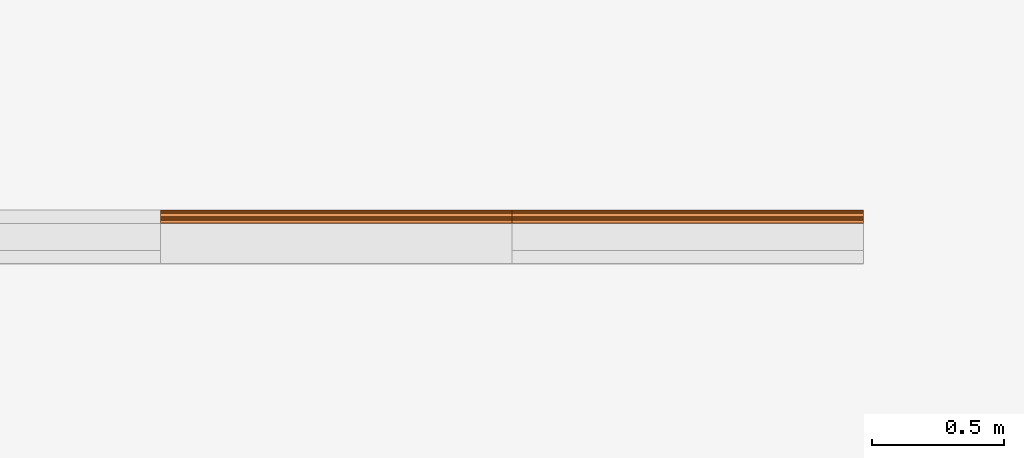
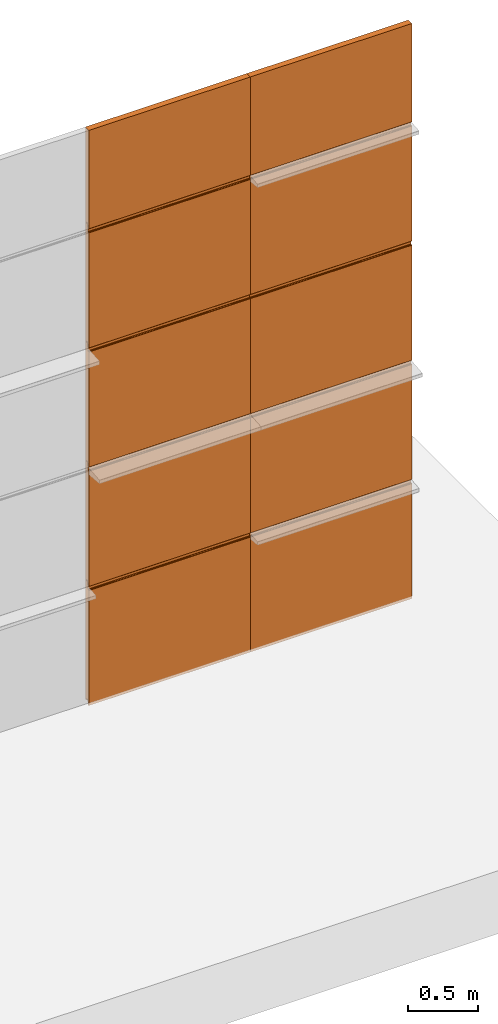
# One storey, part 6 of 6: 10 proxies.
"""IFC2X3 building model written with IfcOpenShell, lengths in millimetres."""

import ifcopenshell
import ifcopenshell.guid

model = None  # the IFC model being written
_history = None  # IfcOwnerHistory: only IFC2X3 demands one
_inside = {}  # id of a spatial element -> (the spatial element, [elements in it])
_under = {}  # id of a project, library or spatial element -> (it, [spatial elements below it])
_declared = {}  # id of a project -> (the project, [libraries it declares])
_typed = {}  # id of a type object -> (the type object, [elements of that type])
_made_of = {}  # id of a material, layer set ... -> (it, [elements and type objects made of it])


def new_model(schema):
    """Start an empty IFC model of exactly this schema.

    Asked for "IFC4X3", IfcOpenShell would pick the latest addendum, in which some entities
    have other attributes; the version numbers below select the first issue.
    IFC2X3 requires an IfcOwnerHistory on every rooted entity: one is made here for all.
    """
    global model, _history
    if schema == "IFC4X3":
        model = ifcopenshell.file(schema_version=(4, 3, 0, 0))
    else:
        model = ifcopenshell.file(schema=schema)
    _inside.clear()
    _under.clear()
    _declared.clear()
    _typed.clear()
    _made_of.clear()
    _history = None
    if model.schema == "IFC2X3":
        org = make("IfcOrganization", Name="unknown")
        user = make(
            "IfcPersonAndOrganization",
            ThePerson=make("IfcPerson", FamilyName="unknown"),
            TheOrganization=org,
        )
        app = make(
            "IfcApplication",
            ApplicationDeveloper=org,
            Version="unknown",
            ApplicationFullName="unknown",
            ApplicationIdentifier="unknown",
        )
        _history = make(
            "IfcOwnerHistory",
            OwningUser=user,
            OwningApplication=app,
            ChangeAction="ADDED",
            CreationDate=0,
        )
    return model


def make(cls, **values):
    """One entity of the class cls with the attributes given. An attribute that is None is left unset."""
    return model.create_entity(
        cls, **{name: value for name, value in values.items() if value is not None}
    )


def entity(cls, *values):
    """Any entity or typed value of the class cls, its attributes in the order of the schema. None: left unset."""
    e = model.create_entity(cls)
    for i, value in enumerate(values):
        if value is not None:
            e[i] = value
    return e


def rooted(cls, **values):
    """An entity with a GlobalId (a new one), such as an element, a storey or a relation."""
    return make(cls, GlobalId=ifcopenshell.guid.new(), OwnerHistory=_history, **values)


def si_unit(unit_type, name, prefix=None):
    """IfcSIUnit, for example si_unit("LENGTHUNIT", "METRE", prefix="MILLI")."""
    return make("IfcSIUnit", UnitType=unit_type, Prefix=prefix, Name=name)


def converted_unit(unit_type, name, factor, base, dimensions=None, offset=None):
    """IfcConversionBasedUnit, such as the inch: factor (a typed value) times the base unit."""
    return make(
        "IfcConversionBasedUnit"
        if offset is None
        else "IfcConversionBasedUnitWithOffset",
        ConversionOffset=offset,
        Dimensions=None
        if dimensions is None
        else entity("IfcDimensionalExponents", *dimensions),
        UnitType=unit_type,
        Name=name,
        ConversionFactor=make(
            "IfcMeasureWithUnit", ValueComponent=factor, UnitComponent=base
        ),
    )


def derived_unit(unit_type, elements):
    """IfcDerivedUnit: a product of units, each with its exponent."""
    return make(
        "IfcDerivedUnit",
        Elements=[
            make("IfcDerivedUnitElement", Unit=unit, Exponent=power)
            for unit, power in elements
        ],
        UnitType=unit_type,
    )


def assignment(units):
    """IfcUnitAssignment: the units of a project."""
    return None if units is None else make("IfcUnitAssignment", Units=units)


def point(xyz):
    """IfcCartesianPoint."""
    return None if xyz is None else make("IfcCartesianPoint", Coordinates=xyz)


def direction(xyz):
    """IfcDirection."""
    return None if xyz is None else make("IfcDirection", DirectionRatios=xyz)


def frame(location, z_axis=None, x_axis=None):
    """IfcAxis2Placement3D, a coordinate frame: its origin and axes. An axis left out is left unset."""
    return make(
        "IfcAxis2Placement3D",
        Location=point(location),
        Axis=direction(z_axis),
        RefDirection=direction(x_axis),
    )


def frame_2d(location, x_axis=None):
    """IfcAxis2Placement2D, a coordinate frame in the plane: its origin and x axis."""
    return make(
        "IfcAxis2Placement2D", Location=point(location), RefDirection=direction(x_axis)
    )


def origin():
    """The frame at (0, 0, 0) with its axes left unset."""
    return frame((0.0, 0.0, 0.0))


def place(relative_to, where):
    """IfcLocalPlacement: puts the frame where relative to a parent placement (None: the world)."""
    return make(
        "IfcLocalPlacement", PlacementRelTo=relative_to, RelativePlacement=where
    )


def context(
    kind, dimensions, precision=None, world=None, true_north=None, identifier=None
):
    """IfcGeometricRepresentationContext, for example the 3D "Model" context."""
    return make(
        "IfcGeometricRepresentationContext",
        ContextIdentifier=identifier,
        ContextType=kind,
        CoordinateSpaceDimension=dimensions,
        Precision=precision,
        WorldCoordinateSystem=world,
        TrueNorth=true_north,
    )


def subcontext(parent, identifier, kind, view, scale=None):
    """IfcGeometricRepresentationSubContext, for example "Body" below "Model"."""
    return make(
        "IfcGeometricRepresentationSubContext",
        ContextIdentifier=identifier,
        ContextType=kind,
        ParentContext=parent,
        TargetScale=scale,
        TargetView=view,
    )


def project(units=None, contexts=None):
    """IfcProject with its units and contexts."""
    return rooted(
        "IfcProject",
        Name="project",
        RepresentationContexts=contexts,
        UnitsInContext=assignment(units),
    )


def spatial(cls, under=None, at=None, **own):
    """A site, building, storey or space (cls), placed at a placement, below another one or the project."""
    s = rooted(cls, ObjectPlacement=at, **own)
    if under is not None:
        _under.setdefault(under.id(), (under, []))[1].append(s)
    return s


def polyline(points):
    """IfcPolyline through the points."""
    return make("IfcPolyline", Points=[point(p) for p in points])


def circle_curve(where, radius):
    """IfcCircle in the frame where."""
    return make("IfcCircle", Position=where, Radius=radius)


def parameter(value):
    """IfcParameterValue: where a trimmed curve begins or ends, as a parameter of its basis curve."""
    return model.create_entity("IfcParameterValue", value)


def trimmed(basis, trim1, trim2, sense, master):
    """IfcTrimmedCurve: the piece of a basis curve between two trims."""
    return make(
        "IfcTrimmedCurve",
        BasisCurve=basis,
        Trim1=trim1,
        Trim2=trim2,
        SenseAgreement=sense,
        MasterRepresentation=master,
    )


def segment(curve, same_sense, transition):
    """IfcCompositeCurveSegment."""
    return make(
        "IfcCompositeCurveSegment",
        Transition=transition,
        SameSense=same_sense,
        ParentCurve=curve,
    )


def composite_curve(segments, self_intersect=None):
    """IfcCompositeCurve: segments joined end to end."""
    return make("IfcCompositeCurve", Segments=segments, SelfIntersect=self_intersect)


def outline(outer, holes=None, kind="AREA"):
    """IfcArbitraryClosedProfileDef: a profile drawn as a closed curve; with holes, ...WithVoids."""
    if holes is None:
        return make("IfcArbitraryClosedProfileDef", ProfileType=kind, OuterCurve=outer)
    return make(
        "IfcArbitraryProfileDefWithVoids",
        ProfileType=kind,
        OuterCurve=outer,
        InnerCurves=holes,
    )


def extrude(swept, where, along, depth):
    """IfcExtrudedAreaSolid: the profile swept, set in the frame where, extruded along a direction by depth."""
    return make(
        "IfcExtrudedAreaSolid",
        SweptArea=swept,
        Position=where,
        ExtrudedDirection=direction(along),
        Depth=depth,
    )


def shape(context_of_items, identifier, shape_type, items):
    """IfcShapeRepresentation: the items that make up one representation, for example the "Body"."""
    return make(
        "IfcShapeRepresentation",
        ContextOfItems=context_of_items,
        RepresentationIdentifier=identifier,
        RepresentationType=shape_type,
        Items=items,
    )


def source(mapping_origin, context_of_items, identifier, shape_type, items):
    """IfcRepresentationMap: a shape defined once, which mapped items show again and again."""
    return make(
        "IfcRepresentationMap",
        MappingOrigin=mapping_origin,
        MappedRepresentation=shape(context_of_items, identifier, shape_type, items),
    )


def transform(
    local_origin,
    x_axis=None,
    y_axis=None,
    z_axis=None,
    scale=None,
    scale2=None,
    scale3=None,
    uniform=True,
):
    """IfcCartesianTransformationOperator3D, or its non-uniform kind. x_axis, y_axis, z_axis: its Axis1, 2, 3."""
    if uniform:
        return make(
            "IfcCartesianTransformationOperator3D",
            Axis1=direction(x_axis),
            Axis2=direction(y_axis),
            LocalOrigin=point(local_origin),
            Scale=scale,
            Axis3=direction(z_axis),
        )
    return make(
        "IfcCartesianTransformationOperator3DnonUniform",
        Axis1=direction(x_axis),
        Axis2=direction(y_axis),
        LocalOrigin=point(local_origin),
        Scale=scale,
        Axis3=direction(z_axis),
        Scale2=scale2,
        Scale3=scale3,
    )


def mapped(mapping_source, mapping_target):
    """IfcMappedItem: shows the shape of a source again, moved by a transform."""
    return make(
        "IfcMappedItem", MappingSource=mapping_source, MappingTarget=mapping_target
    )


def material(Name=None, Category=None):
    """IfcMaterial."""
    return make("IfcMaterial", Name=Name, Category=Category)


def made_of(thing, what):
    """Note that an element or type object is made of a material, layer set ...; save() writes the relation."""
    if what is not None:
        _made_of.setdefault(what.id(), (what, []))[1].append(thing)
    return thing


def type_object(cls, material=None, **own):
    """A type object (cls), such as IfcWallType, which elements share."""
    return made_of(rooted(cls, **own), material)


def type_shapes(of_type, sources):
    """Give a type object the sources (RepresentationMaps) that its elements show as mapped items."""
    of_type.RepresentationMaps = sources


def element(
    cls,
    number,
    at=None,
    inside=None,
    cuts=None,
    type_object=None,
    material=None,
    context=None,
    identifier="Body",
    shape_type=None,
    held_by="IfcProductDefinitionShape",
    body=None,
    shapes=None,
    **own,
):
    """One element of the class cls, such as IfcWall. Its Tag is "e" and its number.

    at: its placement. inside: the storey or other place that contains it. cuts: it is an
    opening in that element (IfcRelVoidsElement). A single representation is given by context,
    identifier, shape_type and body (its items); several are given by shapes. held_by: the class
    of the entity that holds the representations. save() writes the other relations.
    """
    e = rooted(cls, Tag="e%d" % number, ObjectPlacement=at, **own)
    if body is not None:
        shapes = [shape(context, identifier, shape_type, body)]
    if shapes is not None:
        e.Representation = make(held_by, Representations=shapes)
    if inside is not None:
        _inside.setdefault(inside.id(), (inside, []))[1].append(e)
    if cuts is not None:
        rooted(
            "IfcRelVoidsElement", RelatingBuildingElement=cuts, RelatedOpeningElement=e
        )
    if type_object is not None:
        _typed.setdefault(type_object.id(), (type_object, []))[1].append(e)
    return made_of(e, material)


def aggregate(whole, parts):
    """IfcRelAggregates: a whole, such as a stair, and the parts it consists of."""
    return rooted("IfcRelAggregates", RelatingObject=whole, RelatedObjects=parts)


def save(model, path):
    """Write the relations noted so far, then the file.

    IfcRelAggregates (storeys below a building ...), IfcRelContainedInSpatialStructure (elements
    in a storey), IfcRelDefinesByType, IfcRelAssociatesMaterial and IfcRelDeclares: one each for
    every whole, place, type object, material and project.
    """
    for whole, parts in _under.values():
        aggregate(whole, parts)
    for where, things in _inside.values():
        rooted(
            "IfcRelContainedInSpatialStructure",
            RelatedElements=things,
            RelatingStructure=where,
        )
    for kind, things in _typed.values():
        rooted("IfcRelDefinesByType", RelatedObjects=things, RelatingType=kind)
    for what, things in _made_of.values():
        rooted("IfcRelAssociatesMaterial", RelatedObjects=things, RelatingMaterial=what)
    for by, libraries in _declared.values():
        rooted("IfcRelDeclares", RelatingContext=by, RelatedDefinitions=libraries)
    model.write(path)


model = new_model("IFC2X3")

# Units and contexts
model_context = context("Model", 3, precision=0.01, world=origin(), true_north=direction((6.123031769111886e-17, 1.0)))
body_context = subcontext(model_context, "Body", "Model", "MODEL_VIEW")
ifc_project = project(units=[si_unit("LENGTHUNIT", "METRE", prefix="MILLI"), si_unit("AREAUNIT", "SQUARE_METRE"), si_unit("VOLUMEUNIT", "CUBIC_METRE"), converted_unit("PLANEANGLEUNIT", "DEGREE", entity("IfcPlaneAngleMeasure", 0.017453292519943278), si_unit("PLANEANGLEUNIT", "RADIAN"), dimensions=[0, 0, 0, 0, 0, 0, 0]), si_unit("MASSUNIT", "GRAM", prefix="KILO"), derived_unit("MASSDENSITYUNIT", [(si_unit("MASSUNIT", "GRAM", prefix="KILO"), 1), (si_unit("LENGTHUNIT", "METRE"), -3)]), derived_unit("IONCONCENTRATIONUNIT", [(si_unit("MASSUNIT", "GRAM", prefix="KILO"), 1), (si_unit("LENGTHUNIT", "METRE"), -3)]), derived_unit("MOMENTOFINERTIAUNIT", [(si_unit("LENGTHUNIT", "METRE"), 4)]), si_unit("TIMEUNIT", "SECOND"), si_unit("FREQUENCYUNIT", "HERTZ"), si_unit("THERMODYNAMICTEMPERATUREUNIT", "DEGREE_CELSIUS"), derived_unit("THERMALTRANSMITTANCEUNIT", [(si_unit("MASSUNIT", "GRAM", prefix="KILO"), 1), (si_unit("THERMODYNAMICTEMPERATUREUNIT", "KELVIN"), -1), (si_unit("TIMEUNIT", "SECOND"), -3)]), derived_unit("THERMALCONDUCTANCEUNIT", [(si_unit("MASSUNIT", "GRAM", prefix="KILO"), 1), (si_unit("THERMODYNAMICTEMPERATUREUNIT", "KELVIN"), -1), (si_unit("TIMEUNIT", "SECOND"), -3), (si_unit("LENGTHUNIT", "METRE"), 1)]), derived_unit("VOLUMETRICFLOWRATEUNIT", [(si_unit("LENGTHUNIT", "METRE", prefix="DECI"), 3), (si_unit("TIMEUNIT", "SECOND"), -1)]), derived_unit("MASSFLOWRATEUNIT", [(si_unit("MASSUNIT", "GRAM", prefix="KILO"), 1), (si_unit("TIMEUNIT", "SECOND"), -1)]), derived_unit("ROTATIONALFREQUENCYUNIT", [(si_unit("TIMEUNIT", "SECOND"), -1)]), si_unit("ELECTRICCURRENTUNIT", "AMPERE"), si_unit("ELECTRICVOLTAGEUNIT", "VOLT"), si_unit("POWERUNIT", "WATT"), si_unit("FORCEUNIT", "NEWTON", prefix="KILO"), si_unit("ILLUMINANCEUNIT", "LUX"), si_unit("LUMINOUSFLUXUNIT", "LUMEN"), si_unit("LUMINOUSINTENSITYUNIT", "CANDELA"), si_unit("ENERGYUNIT", "JOULE"), derived_unit("USERDEFINED", [(si_unit("MASSUNIT", "GRAM", prefix="KILO"), -1), (si_unit("LENGTHUNIT", "METRE"), -2), (si_unit("TIMEUNIT", "SECOND"), 3), (si_unit("LUMINOUSFLUXUNIT", "LUMEN"), 1)]), derived_unit("USERDEFINED", [(si_unit("MASSUNIT", "GRAM", prefix="KILO"), 1), (si_unit("TIMEUNIT", "SECOND"), -3), (si_unit("LENGTHUNIT", "METRE"), 3), (si_unit("ELECTRICCURRENTUNIT", "AMPERE"), -2)]), derived_unit("SOUNDPOWERUNIT", [(si_unit("MASSUNIT", "GRAM", prefix="KILO"), 1), (si_unit("TIMEUNIT", "SECOND"), -3), (si_unit("LENGTHUNIT", "METRE"), 2)]), derived_unit("SOUNDPRESSUREUNIT", [(si_unit("MASSUNIT", "GRAM", prefix="KILO"), 1), (si_unit("LENGTHUNIT", "METRE"), -1), (si_unit("TIMEUNIT", "SECOND"), -2)]), derived_unit("LINEARVELOCITYUNIT", [(si_unit("LENGTHUNIT", "METRE"), 1), (si_unit("TIMEUNIT", "SECOND"), -1)]), si_unit("PRESSUREUNIT", "PASCAL"), derived_unit("USERDEFINED", [(si_unit("MASSUNIT", "GRAM", prefix="KILO"), 1), (si_unit("LENGTHUNIT", "METRE"), -2), (si_unit("TIMEUNIT", "SECOND"), -2)]), derived_unit("LINEARFORCEUNIT", [(si_unit("MASSUNIT", "GRAM", prefix="KILO"), 1), (si_unit("TIMEUNIT", "SECOND"), -2)]), derived_unit("PLANARFORCEUNIT", [(si_unit("MASSUNIT", "GRAM", prefix="KILO"), 1), (si_unit("LENGTHUNIT", "METRE"), -1), (si_unit("TIMEUNIT", "SECOND"), -2)]), derived_unit("SPECIFICHEATCAPACITYUNIT", [(si_unit("THERMODYNAMICTEMPERATUREUNIT", "KELVIN"), -1), (si_unit("LENGTHUNIT", "METRE"), 2), (si_unit("TIMEUNIT", "SECOND"), -2)]), derived_unit("HEATFLUXDENSITYUNIT", [(si_unit("MASSUNIT", "GRAM", prefix="KILO"), 1), (si_unit("TIMEUNIT", "SECOND"), -3)]), derived_unit("HEATINGVALUEUNIT", [(si_unit("LENGTHUNIT", "METRE"), 2), (si_unit("TIMEUNIT", "SECOND"), -2)]), derived_unit("VAPORPERMEABILITYUNIT", [(si_unit("LENGTHUNIT", "METRE"), -1), (si_unit("TIMEUNIT", "SECOND"), 1)]), derived_unit("DYNAMICVISCOSITYUNIT", [(si_unit("MASSUNIT", "GRAM", prefix="KILO"), 1), (si_unit("TIMEUNIT", "SECOND"), -1), (si_unit("LENGTHUNIT", "METRE"), -1)]), derived_unit("THERMALEXPANSIONCOEFFICIENTUNIT", [(si_unit("THERMODYNAMICTEMPERATUREUNIT", "KELVIN"), -1)]), derived_unit("MODULUSOFELASTICITYUNIT", [(si_unit("MASSUNIT", "GRAM", prefix="KILO"), 1), (si_unit("LENGTHUNIT", "METRE"), -1), (si_unit("TIMEUNIT", "SECOND"), -2)]), derived_unit("ISOTHERMALMOISTURECAPACITYUNIT", [(si_unit("MASSUNIT", "GRAM", prefix="KILO"), -1), (si_unit("LENGTHUNIT", "METRE"), 3)]), derived_unit("MOISTUREDIFFUSIVITYUNIT", [(si_unit("TIMEUNIT", "SECOND"), -1), (si_unit("LENGTHUNIT", "METRE"), 2)]), derived_unit("MASSPERLENGTHUNIT", [(si_unit("MASSUNIT", "GRAM", prefix="KILO"), 1), (si_unit("LENGTHUNIT", "METRE"), -1)]), derived_unit("THERMALRESISTANCEUNIT", [(si_unit("MASSUNIT", "GRAM", prefix="KILO"), -1), (si_unit("TIMEUNIT", "SECOND"), 3), (si_unit("THERMODYNAMICTEMPERATUREUNIT", "KELVIN"), 1)]), derived_unit("ACCELERATIONUNIT", [(si_unit("LENGTHUNIT", "METRE"), 1), (si_unit("TIMEUNIT", "SECOND"), -2)]), derived_unit("ANGULARVELOCITYUNIT", [(si_unit("TIMEUNIT", "SECOND"), -1), (si_unit("PLANEANGLEUNIT", "RADIAN"), 1)]), derived_unit("LINEARSTIFFNESSUNIT", [(si_unit("MASSUNIT", "GRAM", prefix="KILO"), 1), (si_unit("TIMEUNIT", "SECOND"), -2)]), derived_unit("WARPINGCONSTANTUNIT", [(si_unit("LENGTHUNIT", "METRE"), 6)]), derived_unit("LINEARMOMENTUNIT", [(si_unit("MASSUNIT", "GRAM", prefix="KILO"), 1), (si_unit("LENGTHUNIT", "METRE"), 1), (si_unit("TIMEUNIT", "SECOND"), -2)]), derived_unit("TORQUEUNIT", [(si_unit("MASSUNIT", "GRAM", prefix="KILO"), 1), (si_unit("LENGTHUNIT", "METRE"), 2), (si_unit("TIMEUNIT", "SECOND"), -2)])], contexts=[model_context])

# Site, building, storey
site_placement = place(None, origin())
site = spatial("IfcSite", under=ifc_project, at=site_placement, CompositionType="ELEMENT")
building_placement = place(site_placement, origin())
building = spatial("IfcBuilding", under=site, at=building_placement, Name="de", CompositionType="ELEMENT")
storey_placement = place(building_placement, origin())
storey = spatial("IfcBuildingStorey", under=building, at=storey_placement, CompositionType="ELEMENT", Elevation=0.0)

# Proxies
ifc_material = material(Name="KSI_RAL9003")
building_element_proxy_type_1 = type_object("IfcBuildingElementProxyType", Name="Painel Evolution:Painel Evolution", PredefinedType="NOTDEFINED", material=ifc_material)
shared_shape_1 = source(origin(), body_context, "Body", "SweptSolid", [
    extrude(outline(composite_curve([segment(trimmed(circle_curve(frame_2d((-541.6373700065079, 10.459449795313603), x_axis=(-1.0, 0.0)), 1.5999999047686129), [parameter(279.9999998873789)], [parameter(358.50454829316124)], True, "PARAMETER"), True, "CONTINUOUS"), segment(polyline([(-543.2368249510248, 10.501205941207395), (-543.2368249510248, 3.880596964632579)]), True, "CONTINUOUS"), segment(trimmed(circle_curve(frame_2d((-542.1914107086996, 3.880596964632576), x_axis=(-1.0, 0.0)), 1.0454142423252974), [parameter(359.9999999999996)], [parameter(90.00000000000009)], True, "PARAMETER"), True, "CONTINUOUS"), segment(polyline([(-542.1914107086996, 2.83518272230729), (-534.2753031299127, 2.835182722321888)]), True, "CONTINUOUS"), segment(trimmed(circle_curve(frame_2d((-534.2753031299127, 0.485182810658933), x_axis=(-1.0, 0.0)), 2.3499999116629553), [parameter(180.00000000000043)], [parameter(269.9999999999999)], True, "PARAMETER"), False, "CONTINUOUS"), segment(polyline([(-531.9253032182644, 0.4851828106589372), (-531.9253032182644, -3.9178716254091968)]), True, "CONTINUOUS"), segment(trimmed(circle_curve(frame_2d((-534.275303129929, -3.917871625409184), x_axis=(-1.0, 0.0)), 2.3499999116645798), [parameter(90.00000000000009)], [parameter(180.0)], True, "PARAMETER"), False, "CONTINUOUS"), segment(polyline([(-534.275303129929, -6.267871537073788), (-544.9447939910186, -6.267871537074008)]), True, "CONTINUOUS"), segment(trimmed(circle_curve(frame_2d((-544.9447939910186, -8.667871537069942), x_axis=(-1.0, 0.0)), 2.399999999995935), [parameter(269.9999999999999)], [parameter(359.99999999999966)], True, "PARAMETER"), True, "CONTINUOUS"), segment(polyline([(-547.3447939910149, -8.667871537069942), (-547.3447939910149, -10.667871311477809)]), True, "CONTINUOUS"), segment(trimmed(circle_curve(frame_2d((-548.9447939910189, -10.667871311477805), x_axis=(-1.0, 0.0)), 1.6000000000039678), [parameter(90.00000000000009)], [parameter(180.0000000000002)], True, "PARAMETER"), False, "CONTINUOUS"), segment(polyline([(-548.9447939910189, -12.267871311481763), (-572.3355503541303, -12.26787131148627)]), True, "CONTINUOUS"), segment(trimmed(circle_curve(frame_2d((-572.3355503541303, -15.967871172331035), x_axis=(-1.0, 0.0)), 3.699999860844765), [parameter(269.9999999999999)], [parameter(350.4980187502896)], True, "PARAMETER"), True, "CONTINUOUS"), segment(polyline([(-575.9847858236225, -15.357068865127594), (-576.4262167541286, -20.400087371498177)]), True, "CONTINUOUS"), segment(trimmed(circle_curve(frame_2d((-572.8754972220172, -20.700390565940353), x_axis=(-1.0, 0.0)), 3.5633960212569518), [parameter(355.16569651713564)], [parameter(88.83791988883837)], True, "PARAMETER"), True, "CONTINUOUS"), segment(polyline([(-572.9477655073729, -24.26305368488658), (429.0782903905062, -24.26305368490059)]), True, "CONTINUOUS"), segment(trimmed(circle_curve(frame_2d((429.02661432000133, -21.373687559574048), x_axis=(-1.0, 0.0)), 2.889828199469197), [parameter(91.024620965678)], [parameter(174.99921945634426)], True, "PARAMETER"), True, "CONTINUOUS"), segment(polyline([(431.90544241925767, -21.625591901172886), (432.65194514225794, -13.094365331982997)]), True, "CONTINUOUS"), segment(trimmed(circle_curve(frame_2d((434.6718091241544, -13.271108258981247), x_axis=(-1.0, 0.0)), 2.0275819508977904), [parameter(322.50238491495514)], [parameter(354.9992194748408)], True, "PARAMETER"), False, "CONTINUOUS"), segment(trimmed(circle_curve(frame_2d((434.6499261921662, -13.25431834245234), x_axis=(-1.0, 0.0)), 2.000000000331924), [parameter(269.7752197054467)], [parameter(322.50238490067886)], True, "PARAMETER"), False, "CONTINUOUS"), segment(polyline([(434.6577724845074, -11.254333733262063), (464.6446978830772, -11.254333733258877)]), True, "CONTINUOUS"), segment(trimmed(circle_curve(frame_2d((464.6446978830757, -8.454333717516795), x_axis=(-1.0, 0.0)), 2.8000000157420852), [parameter(90.00000000003057)], [parameter(180.00000000002854)], True, "PARAMETER"), True, "CONTINUOUS"), segment(polyline([(467.4446978988198, -8.45433371751389), (467.44469789904696, -6.163773190028205)]), True, "CONTINUOUS"), segment(trimmed(circle_curve(frame_2d((470.4446979072005, -6.163773190028211), x_axis=(-1.0, 0.0)), 3.000000008153628), [parameter(269.9999999999947)], [parameter(4.0711099922733055e-13)], True, "PARAMETER"), False, "CONTINUOUS"), segment(polyline([(470.4446979072011, -3.1637731816474877), (492.4821726913916, -3.1637731816475423)]), True, "CONTINUOUS"), segment(trimmed(circle_curve(frame_2d((492.4821726913916, -4.763773183527278), x_axis=(-1.0, 0.0)), 1.6000000018797356), [parameter(221.0795546756581)], [parameter(270.00000000000233)], True, "PARAMETER"), False, "CONTINUOUS"), segment(trimmed(circle_curve(frame_2d((496.43523715110086, -1.9925479235228443), x_axis=(-1.0, 0.0)), 3.2409633915334344), [parameter(32.05017476117218)], [parameter(61.522805713472586)], True, "PARAMETER"), True, "CONTINUOUS"), segment(trimmed(circle_curve(frame_2d((496.00254394635044, -2.714863509877051), x_axis=(-1.0, 0.0)), 2.4000000000014894), [parameter(62.38069466751207)], [parameter(92.2671756846998)], True, "PARAMETER"), True, "CONTINUOUS"), segment(polyline([(496.0974863986537, -5.11298484349589), (504.442623351026, -5.112984843495904)]), True, "CONTINUOUS"), segment(trimmed(circle_curve(frame_2d((504.4426233510259, -1.8442935298604415), x_axis=(-1.0, 0.0)), 3.268691313635463), [parameter(90.00000000000126)], [parameter(266.64922463269517)], True, "PARAMETER"), True, "CONTINUOUS"), segment(polyline([(504.63367421393616, 1.4188096667328296), (496.7914226707592, 1.4188096667328491)]), True, "CONTINUOUS"), segment(polyline([(496.7914226707592, 1.4188096667328491), (496.79142267075923, 13.229214081882997)]), True, "CONTINUOUS"), segment(polyline([(496.79142267075923, 13.229214081882997), (500.32479033585236, 13.22921408188327)]), True, "CONTINUOUS"), segment(trimmed(circle_curve(frame_2d((499.51496654021736, 16.736946315110515), x_axis=(-1.0, 0.0)), 3.599999999999723), [parameter(102.99999999995242)], [parameter(269.99999999999886)], True, "PARAMETER"), True, "CONTINUOUS"), segment(polyline([(499.5149665402175, 20.336946315110506), (489.7149665402197, 20.33694631511163)]), True, "CONTINUOUS"), segment(trimmed(circle_curve(frame_2d((489.7149665402197, 22.336946315111717), x_axis=(-1.0, 0.0)), 2.0000000000000866), [parameter(3.5622212432391423e-13)], [parameter(90.00000000000202)], True, "PARAMETER"), False, "CONTINUOUS"), segment(polyline([(487.71496654021854, 22.336946315111724), (487.71496654021854, 23.736946315111506)]), True, "CONTINUOUS"), segment(trimmed(circle_curve(frame_2d((485.7149665402189, 23.73694631511151), x_axis=(-1.0, 0.0)), 1.9999999999995453), [parameter(179.99999999999983)], [parameter(269.99999999999795)], True, "PARAMETER"), True, "CONTINUOUS"), segment(polyline([(485.7149665402189, 25.736946315111073), (-547.7850334597792, 25.736946315115553)]), True, "CONTINUOUS"), segment(trimmed(circle_curve(frame_2d((-547.7850334597792, 23.23694631511558), x_axis=(-1.0, 0.0)), 2.499999999999973), [parameter(269.9999999999999)], [parameter(90.00000000000009)], True, "PARAMETER"), True, "CONTINUOUS"), segment(polyline([(-547.7850334597794, 20.736946315117518), (-538.5134802227543, 20.736946315115397)]), True, "CONTINUOUS"), segment(trimmed(circle_curve(frame_2d((-538.5134802227543, 16.38604421100607), x_axis=(-1.0, 0.0)), 4.350902104109325), [parameter(90.00000000000009)], [parameter(269.9999999999999)], True, "PARAMETER"), False, "CONTINUOUS"), segment(polyline([(-538.5134802227543, 12.03514210689464), (-541.9152070711411, 12.03514210689464)]), True, "CONTINUOUS")], self_intersect=False)), frame((-30.32409595977936, -0.7369463151145117, 0.0), z_axis=(0.0, 0.0, -1.0), x_axis=(-1.0, 0.0, 0.0)), (0.0, 0.0, -1.0), 1333.3333333333342),
])
type_shapes(building_element_proxy_type_1, [shared_shape_1])
for number, where, z_axis, x_axis, name in (
    (1, (1654.667810641471, 792.6007792258418, 520.0), (1.0, 0.0, 0.0), (0.0, 0.0, -1.0), "Painel Evolution:Painel Evolution"),
    (2, (1654.667810641471, 792.6007792258426, 1560.0), (1.0, 0.0, 0.0), (0.0, 0.0, -1.0), "Painel Evolution:Painel Evolution"),
    (3, (1654.667810641471, 792.6007792258426, 2600.0), (1.0, 0.0, 0.0), (0.0, 0.0, -1.0), "Painel Evolution:Painel Evolution"),
    (4, (1654.667810641471, 792.6007792258426, 3640.0), (1.0, 0.0, 0.0), (0.0, 0.0, -1.0), "Painel Evolution:Painel Evolution"),
    (5, (2988.0011439748046, 792.6007792258396, 520.0), (1.0, 0.0, 0.0), (0.0, 0.0, -1.0), "Painel Evolution:Painel Evolution"),
    (6, (2988.0011439748046, 792.6007792258396, 1560.0), (1.0, 0.0, 0.0), (0.0, 0.0, -1.0), "Painel Evolution:Painel Evolution"),
    (7, (2988.0011439748046, 792.6007792258396, 2600.0), (1.0, 0.0, 0.0), (0.0, 0.0, -1.0), "Painel Evolution:Painel Evolution"),
    (8, (2988.0011439748046, 792.6007792258396, 3640.0), (1.0, 0.0, 0.0), (0.0, 0.0, -1.0), "Painel Evolution:Painel Evolution"),
):
    element("IfcBuildingElementProxy", number, at=place(storey_placement, frame(where, z_axis=z_axis, x_axis=x_axis)), inside=storey, type_object=building_element_proxy_type_1, material=ifc_material, Name=name, ObjectType="Painel Evolution:Painel Evolution", context=body_context, shape_type="MappedRepresentation", body=[
        mapped(shared_shape_1, transform((0.0, 0.0, 0.0), scale=1.0)),
    ])
building_element_proxy_type_2 = type_object("IfcBuildingElementProxyType", Name="Painel Evolution:Painel Evolution", PredefinedType="NOTDEFINED", material=ifc_material)
shared_shape_2 = source(origin(), body_context, "Body", "SweptSolid", [
    extrude(outline(composite_curve([segment(trimmed(circle_curve(frame_2d((-69.24830272831227, 10.78003811995571), x_axis=(-1.0, 0.0)), 1.5999999047686129), [parameter(279.9999998873789)], [parameter(358.50454829316124)], True, "PARAMETER"), True, "CONTINUOUS"), segment(polyline([(-70.84775767282915, 10.821794265849501), (-70.84775767282916, 4.201185289274686)]), True, "CONTINUOUS"), segment(trimmed(circle_curve(frame_2d((-69.80234343050391, 4.201185289274683), x_axis=(-1.0, 0.0)), 1.0454142423252974), [parameter(359.9999999999996)], [parameter(90.00000000000009)], True, "PARAMETER"), True, "CONTINUOUS"), segment(polyline([(-69.80234343050385, 3.1557710469493974), (-61.88623585171705, 3.1557710469639955)]), True, "CONTINUOUS"), segment(trimmed(circle_curve(frame_2d((-61.88623585171706, 0.8057711353010405), x_axis=(-1.0, 0.0)), 2.3499999116629553), [parameter(180.00000000000043)], [parameter(269.9999999999999)], True, "PARAMETER"), False, "CONTINUOUS"), segment(polyline([(-59.536235940068764, 0.8057711353010448), (-59.53623594006877, -3.59728330076709)]), True, "CONTINUOUS"), segment(trimmed(circle_curve(frame_2d((-61.886235851733325, -3.5972833007670766), x_axis=(-1.0, 0.0)), 2.3499999116645798), [parameter(90.00000000000009)], [parameter(180.0)], True, "PARAMETER"), False, "CONTINUOUS"), segment(polyline([(-61.88623585173333, -5.947283212431681), (-72.55572671282302, -5.947283212431901)]), True, "CONTINUOUS"), segment(trimmed(circle_curve(frame_2d((-72.55572671282302, -8.347283212427834), x_axis=(-1.0, 0.0)), 2.399999999995935), [parameter(269.9999999999999)], [parameter(359.99999999999966)], True, "PARAMETER"), True, "CONTINUOUS"), segment(polyline([(-74.95572671281924, -8.347283212427834), (-74.95572671281926, -10.347282986835701)]), True, "CONTINUOUS"), segment(trimmed(circle_curve(frame_2d((-76.55572671282326, -10.3472829868357), x_axis=(-1.0, 0.0)), 1.6000000000039678), [parameter(90.00000000000009)], [parameter(180.0000000000002)], True, "PARAMETER"), False, "CONTINUOUS"), segment(polyline([(-76.55572671282326, -11.947282986839657), (-99.94648307593471, -11.947282986844161)]), True, "CONTINUOUS"), segment(trimmed(circle_curve(frame_2d((-99.94648307593472, -15.647282847688928), x_axis=(-1.0, 0.0)), 3.699999860844765), [parameter(269.9999999999999)], [parameter(350.4980187502896)], True, "PARAMETER"), True, "CONTINUOUS"), segment(polyline([(-103.59571854542689, -15.036480540485487), (-104.03714947593306, -20.07949904685607)]), True, "CONTINUOUS"), segment(trimmed(circle_curve(frame_2d((-100.48642994382163, -20.379802241298247), x_axis=(-1.0, 0.0)), 3.5633960212569518), [parameter(355.16569651713564)], [parameter(88.83791988883837)], True, "PARAMETER"), True, "CONTINUOUS"), segment(polyline([(-100.5586982291772, -23.942465360244473), (757.0353282913596, -23.942465360256467)]), True, "CONTINUOUS"), segment(polyline([(757.0353282913596, -23.942465360256467), (757.0353282913599, 26.057534639754053)]), True, "CONTINUOUS"), segment(polyline([(757.0353282913599, 26.057534639754053), (-75.39596618158366, 26.057534639757662)]), True, "CONTINUOUS"), segment(trimmed(circle_curve(frame_2d((-75.39596618158367, 23.55753463975769), x_axis=(-1.0, 0.0)), 2.499999999999973), [parameter(269.9999999999999)], [parameter(90.00000000000009)], True, "PARAMETER"), True, "CONTINUOUS"), segment(polyline([(-75.39596618158367, 21.057534639759627), (-66.12441294455857, 21.057534639757503)]), True, "CONTINUOUS"), segment(trimmed(circle_curve(frame_2d((-66.12441294455859, 16.706632535648176), x_axis=(-1.0, 0.0)), 4.350902104109325), [parameter(90.00000000000009)], [parameter(269.9999999999999)], True, "PARAMETER"), False, "CONTINUOUS"), segment(polyline([(-66.1244129445586, 12.355730431536747), (-69.52613979294549, 12.355730431536745)]), True, "CONTINUOUS")], self_intersect=False)), frame((442.06497131841627, -1.057534639757794, 0.0), z_axis=(0.0, 0.0, -1.0), x_axis=(-1.0, 0.0, 0.0)), (0.0, 0.0, -1.0), 1333.3333333333337),
])
type_shapes(building_element_proxy_type_2, [shared_shape_2])
for number, where, z_axis, x_axis, name in (
    (9, (1654.6678106414715, 792.6007792258425, 4680.0), (1.0, 0.0, 0.0), (0.0, 0.0, -1.0), "Painel Evolution:Painel Evolution"),
    (10, (2988.0011439748046, 792.6007792258395, 4680.0), (1.0, 0.0, 0.0), (0.0, 0.0, -1.0), "Painel Evolution:Painel Evolution"),
):
    element("IfcBuildingElementProxy", number, at=place(storey_placement, frame(where, z_axis=z_axis, x_axis=x_axis)), inside=storey, type_object=building_element_proxy_type_2, material=ifc_material, Name=name, ObjectType="Painel Evolution:Painel Evolution", context=body_context, shape_type="MappedRepresentation", body=[
        mapped(shared_shape_2, transform((0.0, 0.0, 0.0), scale=1.0)),
    ])

save(model, "model.ifc")
